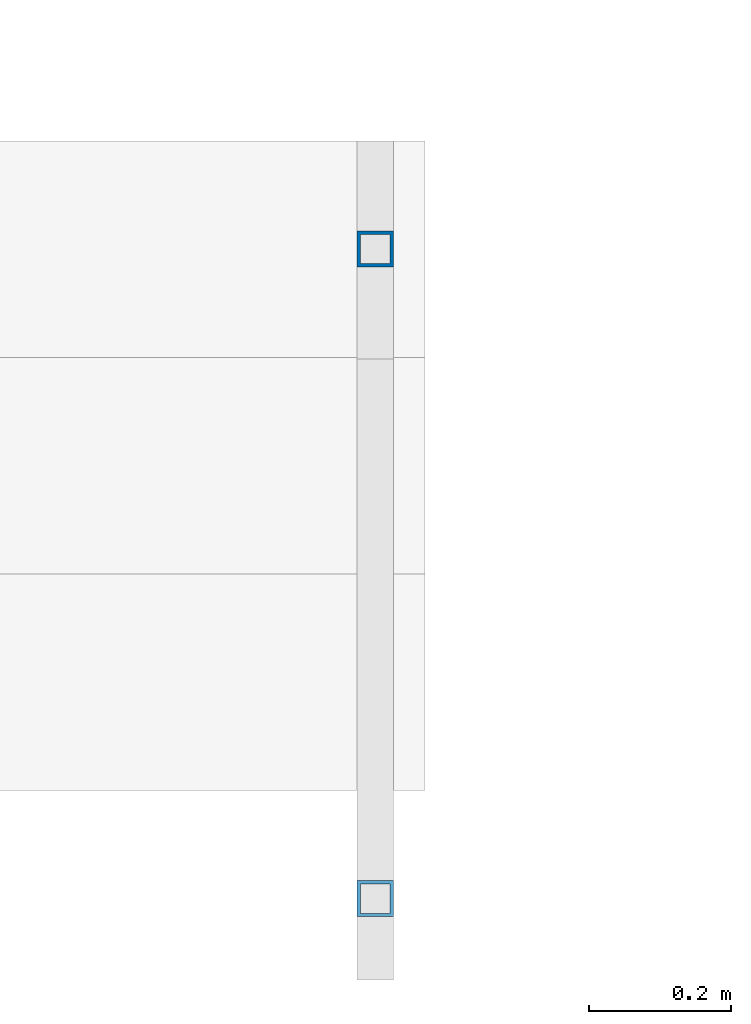
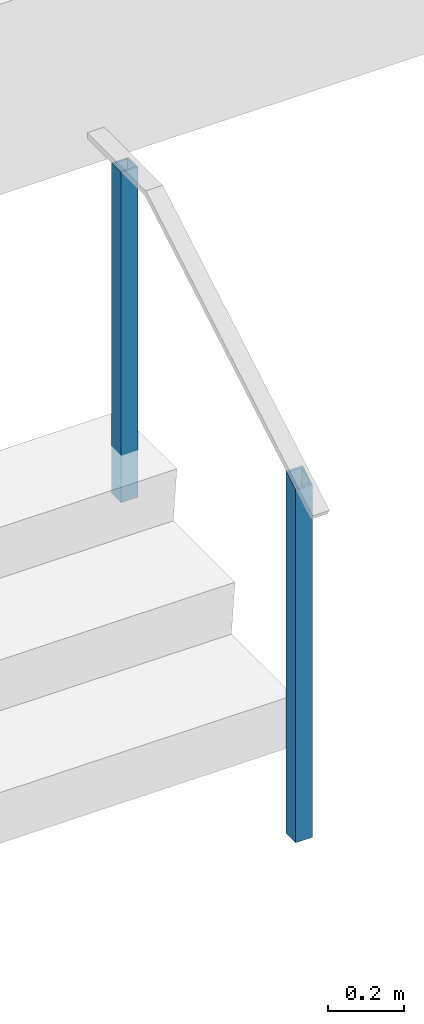
# One storey, part 894 of 1763: 2 columns, 1 element without a shape of its own.
"""IFC2X3 building model written with IfcOpenShell, lengths in millimetres."""

from ifc_helpers import new_model, si_unit, frame, origin_with_axes, place, context, subcontext, project, spatial, faceted_brep, material, type_object, element, aggregate, save


model = new_model("IFC2X3")

# Units and contexts
model_context = context("Model", 3, precision=1e-05, world=origin_with_axes())
body_context = subcontext(model_context, "Body", "Model", "MODEL_VIEW")
ifc_project = project(units=[si_unit("LENGTHUNIT", "METRE", prefix="MILLI"), si_unit("AREAUNIT", "SQUARE_METRE"), si_unit("VOLUMEUNIT", "CUBIC_METRE"), si_unit("MASSUNIT", "GRAM", prefix="KILO"), si_unit("TIMEUNIT", "SECOND"), si_unit("PLANEANGLEUNIT", "RADIAN"), si_unit("SOLIDANGLEUNIT", "STERADIAN"), si_unit("THERMODYNAMICTEMPERATUREUNIT", "DEGREE_CELSIUS"), si_unit("LUMINOUSINTENSITYUNIT", "LUMEN")], contexts=[model_context])

# Site, building, storey
site_placement = place(None, origin_with_axes())
site = spatial("IfcSite", under=ifc_project, at=site_placement, CompositionType="ELEMENT")
building_placement = place(site_placement, origin_with_axes())
building = spatial("IfcBuilding", under=site, at=building_placement, Name="Undefined", CompositionType="ELEMENT")
storey_placement = place(building_placement, origin_with_axes())
storey = spatial("IfcBuildingStorey", under=building, at=storey_placement, Name="Undefined", CompositionType="ELEMENT", Elevation=0.0)

# Assembly, columns
assembly_placement = place(storey_placement, origin_with_axes())
assembly = element("IfcElementAssembly", 1, at=assembly_placement, inside=storey, Name="HANDRAIL", AssemblyPlace="NOTDEFINED", PredefinedType="RIGID_FRAME")
ifc_material = material()
column_type = type_object("IfcColumnType", Name="2X2X3/16 SQUARE TUBE SS", PredefinedType="NOTDEFINED")
column_1_placement = place(assembly_placement, frame((-45509.8872736984, -19034.1249975692, 4114.8), z_axis=(-1.0, 0.0, 0.0), x_axis=(0.0, 0.0, 1.0)))
column_1 = element("IfcColumn", 2, at=column_1_placement, type_object=column_type, material=ifc_material, Name="POST TUBE", ObjectType="2X2X3/16 SQUARE TUBE SS", context=body_context, shape_type="Brep", body=[
    faceted_brep([(0.0, 20.6375000000007, -20.6374999999971), (0.0, -20.6375000000007, -20.6374999999971), (1132.63432765349, -20.6375000000007, -20.6374999999971), (1156.71140979222, 20.6375000000007, -20.6374999999971), (0.0, -20.6375000000007, 20.6374999999971), (1132.63432765349, -20.6375000000007, 20.6374999999971), (0.0, 20.6375000000007, 20.6374999999971), (1156.71140979222, 20.6375000000007, 20.6374999999971), (-1.45519152283669e-11, 25.4000000000015, -25.3999999999869), (1.45519152283669e-11, 25.4000000000015, 25.3999999999796), (1159.48953465438, 25.4000000000015, 25.4000000000015), (1159.48953465438, 25.4000000000015, -25.4000000000015), (0.0, -25.4000000000015, 25.3999999999942), (1129.85620279133, -25.4000000000015, 25.4000000000015), (-1.45519152283669e-11, -25.4000000000015, -25.3999999999869), (1129.85620279133, -25.4000000000015, -25.4000000000015)], [[[0, 1, 2, 3]], [[1, 4, 5, 2]], [[4, 6, 7, 5]], [[6, 0, 3, 7]], [[8, 9, 10, 11]], [[9, 12, 13, 10]], [[12, 14, 15, 13]], [[14, 8, 11, 15]], [[13, 15, 11, 10], [5, 7, 3, 2]], [[14, 12, 9, 8], [6, 4, 1, 0]]]),
])
column_2_placement = place(assembly_placement, frame((-45509.8872736984, -18119.7249975692, 4648.19997558594), z_axis=(-1.0, 0.0, 0.0), x_axis=(0.0, 0.0, 1.0)))
column_2 = element("IfcColumn", 3, at=column_2_placement, type_object=column_type, material=ifc_material, Name="POST TUBE", ObjectType="2X2X3/16 SQUARE TUBE SS", context=body_context, shape_type="Brep", body=[
    faceted_brep([(-1.45519152283669e-11, -25.4000000000015, -25.3999999999869), (-1.45519152283669e-11, 25.4000000000015, -25.3999999999869), (1057.27498047955, 25.4000000000015, -25.4000000000015), (1057.27498047955, -25.4000000000015, -25.4000000000015), (0.0, -25.4000000000015, 25.3999999999942), (1057.27498047955, -25.4000000000015, 25.4000000000015), (1.45519152283669e-11, 25.4000000000015, 25.3999999999796), (1057.27498047955, 25.4000000000015, 25.4000000000015), (0.0, 20.6375000000007, 20.6374999999971), (0.0, -20.6375000000007, 20.6374999999971), (0.0, -20.6375000000007, -20.6374999999971), (0.0, 20.6375000000007, -20.6374999999971), (1057.27498047955, -20.6375000000007, 20.6374999999971), (1057.27498047955, -20.6375000000007, -20.6374999999971), (1057.27498047955, 20.6375000000007, -20.6374999999971), (1057.27498047955, 20.6375000000007, 20.6374999999971)], [[[0, 1, 2, 3]], [[4, 0, 3, 5]], [[6, 4, 5, 7]], [[1, 6, 7, 2]], [[0, 4, 6, 1], [8, 9, 10, 11]], [[10, 9, 12, 13]], [[11, 10, 13, 14]], [[8, 11, 14, 15]], [[9, 8, 15, 12]], [[2, 7, 5, 3], [14, 13, 12, 15]]]),
])
aggregate(assembly, [column_1, column_2])

save(model, "model.ifc")
